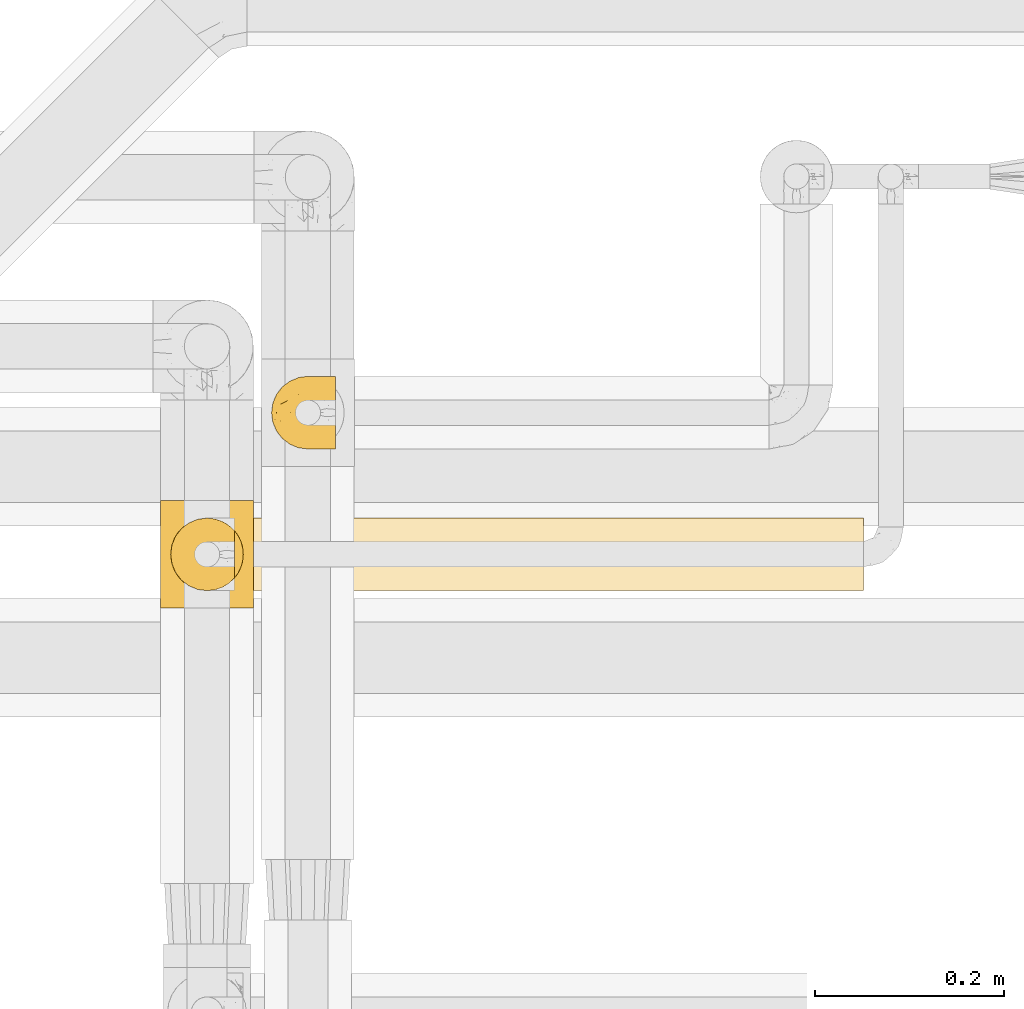
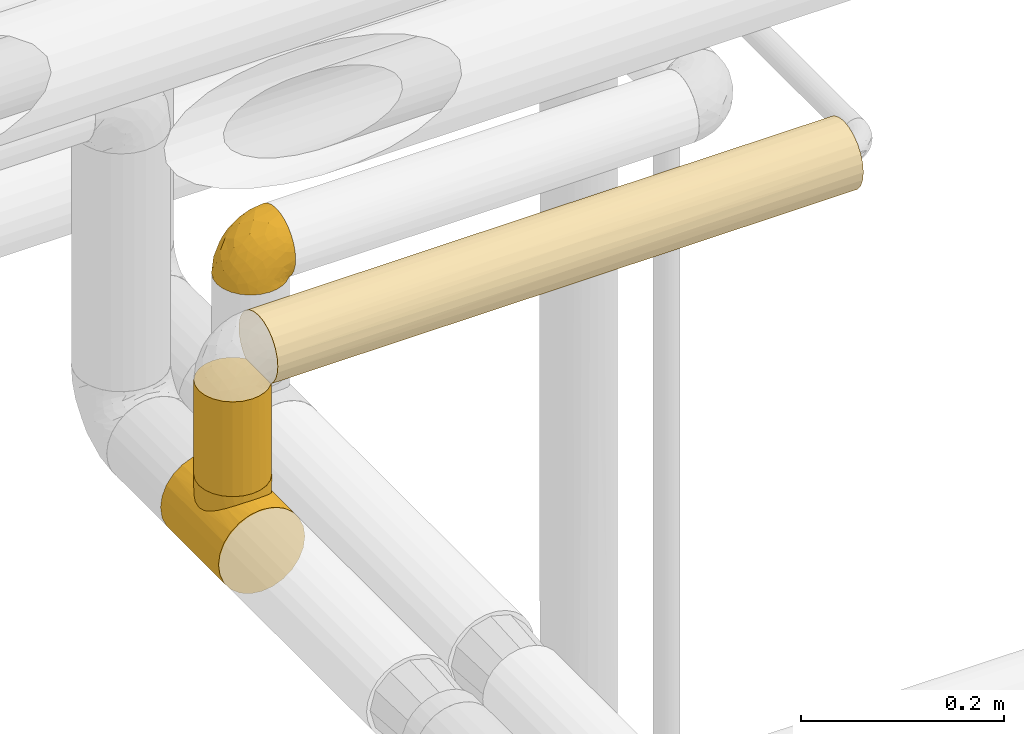
# One storey, part 374 of 827: 4 coverings.
"""IFC2X3 building model written with IfcOpenShell, lengths in millimetres."""

from ifc_helpers import new_model, entity, si_unit, converted_unit, derived_unit, direction, frame, origin, place, context, subcontext, project, spatial, faceted_brep, element, save


model = new_model("IFC2X3")

# Units and contexts
model_context = context("Model", 3, precision=0.01, world=origin(), true_north=direction((6.12303176911189e-17, 1.0)))
body_context = subcontext(model_context, "Body", "Model", "MODEL_VIEW")
ifc_project = project(units=[si_unit("LENGTHUNIT", "METRE", prefix="MILLI"), si_unit("AREAUNIT", "SQUARE_METRE"), si_unit("VOLUMEUNIT", "CUBIC_METRE"), converted_unit("PLANEANGLEUNIT", "DEGREE", entity("IfcRatioMeasure", 0.0174532925199433), si_unit("PLANEANGLEUNIT", "RADIAN"), dimensions=[0, 0, 0, 0, 0, 0, 0]), si_unit("MASSUNIT", "GRAM", prefix="KILO"), derived_unit("MASSDENSITYUNIT", [(si_unit("MASSUNIT", "GRAM", prefix="KILO"), 1), (si_unit("LENGTHUNIT", "METRE"), -3)]), derived_unit("MOMENTOFINERTIAUNIT", [(si_unit("LENGTHUNIT", "METRE"), 4)]), si_unit("TIMEUNIT", "SECOND"), si_unit("FREQUENCYUNIT", "HERTZ"), si_unit("THERMODYNAMICTEMPERATUREUNIT", "DEGREE_CELSIUS"), derived_unit("THERMALTRANSMITTANCEUNIT", [(si_unit("MASSUNIT", "GRAM", prefix="KILO"), 1), (si_unit("THERMODYNAMICTEMPERATUREUNIT", "KELVIN"), -1), (si_unit("TIMEUNIT", "SECOND"), -3)]), derived_unit("VOLUMETRICFLOWRATEUNIT", [(si_unit("LENGTHUNIT", "METRE"), 3), (si_unit("TIMEUNIT", "SECOND"), -1)]), derived_unit("MASSFLOWRATEUNIT", [(si_unit("MASSUNIT", "GRAM", prefix="KILO"), 1), (si_unit("TIMEUNIT", "SECOND"), -1)]), derived_unit("ROTATIONALFREQUENCYUNIT", [(si_unit("TIMEUNIT", "SECOND"), -1)]), si_unit("ELECTRICCURRENTUNIT", "AMPERE"), si_unit("ELECTRICVOLTAGEUNIT", "VOLT"), si_unit("POWERUNIT", "WATT"), si_unit("FORCEUNIT", "NEWTON", prefix="KILO"), si_unit("ILLUMINANCEUNIT", "LUX"), si_unit("LUMINOUSFLUXUNIT", "LUMEN"), si_unit("LUMINOUSINTENSITYUNIT", "CANDELA"), derived_unit("USERDEFINED", [(si_unit("MASSUNIT", "GRAM", prefix="KILO"), -1), (si_unit("LENGTHUNIT", "METRE"), -2), (si_unit("TIMEUNIT", "SECOND"), 3), (si_unit("LUMINOUSFLUXUNIT", "LUMEN"), 1)]), derived_unit("LINEARVELOCITYUNIT", [(si_unit("LENGTHUNIT", "METRE"), 1), (si_unit("TIMEUNIT", "SECOND"), -1)]), si_unit("PRESSUREUNIT", "PASCAL"), derived_unit("USERDEFINED", [(si_unit("LENGTHUNIT", "METRE"), -2), (si_unit("MASSUNIT", "GRAM", prefix="KILO"), 1), (si_unit("TIMEUNIT", "SECOND"), -2)]), derived_unit("LINEARFORCEUNIT", [(si_unit("MASSUNIT", "GRAM", prefix="KILO"), 1), (si_unit("LENGTHUNIT", "METRE"), 1), (si_unit("TIMEUNIT", "SECOND"), -2), (si_unit("LENGTHUNIT", "METRE"), -1)]), derived_unit("PLANARFORCEUNIT", [(si_unit("MASSUNIT", "GRAM", prefix="KILO"), 1), (si_unit("LENGTHUNIT", "METRE"), 1), (si_unit("TIMEUNIT", "SECOND"), -2), (si_unit("LENGTHUNIT", "METRE"), -2)])], contexts=[model_context])

# Site, building, storey
site_placement = place(None, origin())
site = spatial("IfcSite", under=ifc_project, at=site_placement, CompositionType="ELEMENT")
building_placement = place(site_placement, origin())
building = spatial("IfcBuilding", under=site, at=building_placement, CompositionType="ELEMENT")
storey_placement = place(building_placement, frame((0.0, 0.0, 28200.0)))
storey = spatial("IfcBuildingStorey", under=building, at=storey_placement, Name="08", CompositionType="ELEMENT", Elevation=28200.0)

# Coverings
covering_1_placement = place(storey_placement, frame((41436.17, 18826.17, 3169.3)))
element("IfcCovering", 1, at=covering_1_placement, inside=storey, Name=":ADSK_", ObjectType=":ADSK_", PredefinedType="INSULATION", context=body_context, shape_type="Brep", body=[
    faceted_brep([(69.15, 74.68, 47.38), (69.15, 70.1, 54.67), (69.15, 64.01, 60.76), (69.15, 56.72, 65.34), (69.15, 48.6, 68.18), (69.15, 40.05, 69.15), (69.15, 31.49, 68.18), (69.15, 23.36, 65.33), (69.15, 16.07, 60.75), (69.15, 9.98, 54.66), (69.15, 5.4, 47.37), (69.15, 2.56, 39.25), (69.15, 1.6, 30.7), (69.15, 2.46, 22.59), (69.15, 5.01, 14.86), (69.15, 9.13, 7.84), (69.15, 14.62, 1.85), (69.15, 16.82, 1.85), (69.15, 18.56, 1.85), (69.15, 20.52, 1.85), (69.15, 22.49, 1.85), (69.15, 24.46, 1.85), (69.15, 26.42, 1.85), (69.15, 28.39, 1.85), (69.15, 30.36, 1.85), (69.15, 32.55, 1.85), (69.15, 34.75, 1.85), (69.15, 36.94, 1.85), (69.15, 39.13, 1.85), (69.15, 41.33, 1.85), (69.15, 43.52, 1.85), (69.15, 45.72, 1.85), (69.15, 47.91, 1.85), (69.15, 50.11, 1.85), (69.15, 52.3, 1.85), (69.15, 54.49, 1.85), (69.15, 56.69, 1.85), (69.15, 58.88, 1.85), (69.15, 61.08, 1.85), (69.15, 63.27, 1.85), (69.15, 65.47, 1.85), (69.15, 70.97, 7.85), (69.15, 75.09, 14.88), (69.15, 77.64, 22.61), (69.15, 78.5, 30.7), (69.15, 77.53, 39.26), (68.89, 14.62, 1.6), (62.89, 9.12, 1.6), (55.87, 5.0, 1.6), (48.14, 2.46, 1.6), (40.05, 1.6, 1.6), (30.09, 2.91, 1.6), (20.82, 6.75, 1.6), (12.86, 12.86, 1.6), (6.75, 20.82, 1.6), (2.91, 30.09, 1.6), (1.6, 40.05, 1.6), (2.91, 50.0, 1.6), (6.75, 59.27, 1.6), (12.86, 67.23, 1.6), (20.82, 73.34, 1.6), (30.09, 77.19, 1.6), (40.05, 78.5, 1.6), (48.14, 77.63, 1.6), (55.87, 75.09, 1.6), (62.89, 70.97, 1.6), (68.89, 65.47, 1.6), (68.89, 63.27, 1.6), (68.89, 62.29, 1.6), (68.89, 60.7, 1.6), (68.89, 59.11, 1.6), (68.89, 57.52, 1.6), (68.89, 55.93, 1.6), (68.89, 54.34, 1.6), (68.89, 52.76, 1.6), (68.89, 51.17, 1.6), (68.89, 49.58, 1.6), (68.89, 47.99, 1.6), (68.89, 46.4, 1.6), (68.89, 44.81, 1.6), (68.89, 43.22, 1.6), (68.89, 41.63, 1.6), (68.89, 40.05, 1.6), (68.89, 38.46, 1.6), (68.89, 36.87, 1.6), (68.89, 35.28, 1.6), (68.89, 33.69, 1.6), (68.89, 32.1, 1.6), (68.89, 30.51, 1.6), (68.89, 28.92, 1.6), (68.89, 27.33, 1.6), (68.89, 25.37, 1.6), (68.89, 23.4, 1.6), (68.89, 21.21, 1.6), (68.89, 19.01, 1.6), (68.89, 16.82, 1.6), (68.97, 42.32, 1.78), (68.96, 44.02, 1.77), (68.97, 47.13, 1.78), (68.97, 48.74, 1.77), (68.98, 23.57, 1.79), (68.97, 25.13, 1.78), (68.96, 61.34, 1.76), (68.96, 22.02, 1.77), (68.96, 29.72, 1.77), (68.96, 56.73, 1.76), (68.96, 55.14, 1.77), (68.96, 37.66, 1.77), (69.0, 64.12, 1.8), (68.96, 28.13, 1.76), (68.96, 26.62, 1.77), (68.97, 31.46, 1.78), (68.96, 16.16, 1.77), (68.96, 39.16, 1.77), (68.96, 50.37, 1.76), (68.97, 17.69, 1.77), (68.97, 19.17, 1.78), (68.97, 62.78, 1.77), (68.96, 58.35, 1.77), (68.96, 45.53, 1.77), (68.97, 59.91, 1.78), (68.97, 65.47, 1.77), (69.02, 65.47, 1.8), (69.08, 65.47, 1.82), (68.97, 14.62, 1.77), (68.94, 14.62, 1.72), (68.92, 14.62, 1.66), (68.96, 20.59, 1.76), (68.96, 32.99, 1.77), (68.95, 34.48, 1.76), (68.96, 51.91, 1.77), (68.92, 65.47, 1.66), (68.94, 65.47, 1.72), (68.98, 53.48, 1.78), (69.08, 14.62, 1.82), (69.02, 14.62, 1.8), (68.96, 40.77, 1.77), (68.97, 35.97, 1.78), (61.33, 7.84, 3.72), (53.1, 3.53, 7.41), (63.33, 8.32, 6.13), (55.53, 2.19, 19.34), (63.33, 3.53, 17.64), (54.6, 1.6, 26.8), (41.99, 1.6, 8.87), (57.07, 4.57, 9.2), (57.95, 3.96, 12.79), (51.56, 2.28, 14.62), (41.58, 1.6, 7.34), (61.7, 7.69, 5.33), (65.0, 8.32, 7.7), (67.02, 7.84, 9.41), (61.87, 1.6, 28.75), (49.27, 1.6, 21.47), (43.94, 1.6, 16.15), (61.21, 4.34, 14.14), (63.4, 1.6, 29.16), (33.11, 29.63, 57.02), (52.82, 27.34, 64.92), (43.3, 40.05, 64.0), (33.73, 2.39, 11.92), (36.52, 2.43, 19.16), (24.87, 9.07, 28.65), (14.17, 16.64, 24.62), (18.43, 9.54, 15.19), (28.67, 4.52, 18.36), (26.0, 4.52, 9.2), (49.25, 7.49, 46.98), (59.72, 7.49, 50.24), (55.1, 12.85, 56.1), (44.72, 2.35, 28.97), (34.15, 22.66, 54.46), (5.25, 32.9, 21.34), (6.75, 25.33, 18.4), (55.54, 40.05, 66.44), (10.47, 16.64, 12.07), (25.49, 19.99, 45.49), (35.53, 16.37, 50.57), (48.22, 3.26, 36.04), (58.71, 3.75, 42.07), (57.42, 19.58, 62.12), (34.84, 7.5, 37.37), (36.87, 4.04, 29.39), (45.01, 13.94, 53.59), (44.4, 19.58, 58.06), (23.96, 28.21, 49.27), (11.2, 24.75, 29.63), (10.56, 31.42, 33.21), (16.81, 26.2, 40.1), (17.38, 33.36, 44.08), (21.38, 40.05, 49.36), (32.34, 40.05, 56.68), (4.3, 40.05, 15.2), (20.65, 16.14, 35.57), (29.66, 12.85, 41.7), (39.6, 10.47, 46.4), (42.55, 6.49, 41.41), (6.74, 40.05, 27.45), (14.06, 40.05, 38.4), (26.84, 75.57, 12.99), (5.28, 47.37, 21.33), (18.52, 52.91, 42.89), (33.13, 50.46, 57.04), (55.1, 67.23, 56.11), (57.43, 60.5, 62.13), (20.72, 70.55, 21.89), (11.46, 63.45, 16.62), (17.69, 62.61, 32.9), (49.26, 72.6, 46.99), (59.73, 72.6, 50.25), (58.71, 76.34, 42.08), (29.72, 59.34, 49.91), (35.35, 77.76, 15.6), (43.94, 78.5, 16.15), (41.99, 78.5, 8.87), (63.4, 78.5, 29.16), (4.93, 53.16, 13.16), (17.46, 70.55, 10.83), (10.94, 48.88, 33.8), (8.92, 54.76, 25.02), (52.83, 52.74, 64.92), (29.34, 71.93, 32.83), (30.26, 75.79, 20.56), (44.4, 60.5, 58.07), (39.06, 77.86, 21.46), (43.06, 77.64, 28.1), (54.6, 78.5, 26.8), (49.27, 78.5, 21.47), (42.69, 67.23, 51.29), (48.2, 76.82, 36.04), (61.87, 78.5, 28.75), (33.44, 77.8, 8.45), (29.67, 67.23, 41.73), (38.5, 73.2, 39.27), (23.35, 67.66, 33.56), (34.97, 75.99, 27.29), (53.1, 76.57, 7.41), (59.68, 73.21, 3.51), (62.19, 71.93, 4.68), (64.11, 71.07, 5.52), (57.97, 75.09, 8.75), (57.95, 76.13, 12.79), (63.33, 76.57, 17.65), (51.77, 77.69, 13.9), (67.02, 72.26, 9.42), (64.98, 71.77, 7.68), (55.53, 77.9, 19.33), (61.22, 75.75, 14.13)], [[[0, 1, 2, 3, 4, 5, 6, 7, 8, 9, 10, 11, 12, 13, 14, 15, 16, 17, 18, 19, 20, 21, 22, 23, 24, 25, 26, 27, 28, 29, 30, 31, 32, 33, 34, 35, 36, 37, 38, 39, 40, 41, 42, 43, 44, 45]], [[46, 47, 48, 49, 50, 51, 52, 53, 54, 55, 56, 57, 58, 59, 60, 61, 62, 63, 64, 65, 66, 67, 68, 69, 70, 71, 72, 73, 74, 75, 76, 77, 78, 79, 80, 81, 82, 83, 84, 85, 86, 87, 88, 89, 90, 91, 92, 93, 94, 95]], [[96, 97, 30]], [[98, 77, 99]], [[100, 101, 21]], [[69, 68, 102]], [[20, 19, 103]], [[24, 23, 104]], [[20, 103, 100]], [[72, 105, 106]], [[84, 83, 107]], [[89, 88, 104]], [[108, 67, 66]], [[109, 110, 90]], [[111, 25, 24]], [[112, 17, 16]], [[82, 113, 83]], [[109, 23, 22]], [[114, 76, 75]], [[105, 36, 106]], [[104, 111, 24]], [[18, 115, 116]], [[97, 96, 80]], [[67, 108, 117]], [[105, 71, 118]], [[31, 97, 119]], [[102, 120, 69]], [[108, 121, 122, 123, 40]], [[112, 95, 115]], [[17, 115, 18]], [[94, 116, 115]], [[117, 68, 67]], [[38, 117, 39]], [[112, 124, 125, 126, 46]], [[17, 112, 115]], [[70, 120, 118]], [[39, 117, 108]], [[120, 38, 37]], [[120, 37, 118]], [[120, 70, 69]], [[116, 94, 127]], [[128, 86, 129]], [[117, 38, 102]], [[74, 130, 75]], [[99, 33, 32]], [[115, 95, 94]], [[39, 108, 40]], [[108, 66, 131, 132, 121]], [[105, 72, 71]], [[118, 37, 36]], [[71, 70, 118]], [[35, 106, 36]], [[36, 105, 118]], [[35, 133, 106]], [[74, 73, 133]], [[106, 133, 73]], [[99, 114, 33]], [[133, 35, 34]], [[73, 72, 106]], [[95, 112, 46]], [[112, 16, 134, 135, 124]], [[130, 114, 75]], [[99, 76, 114]], [[114, 130, 33]], [[34, 33, 130]], [[78, 77, 98]], [[98, 119, 78]], [[130, 133, 34]], [[133, 130, 74]], [[79, 97, 80]], [[98, 99, 32]], [[98, 32, 31]], [[77, 76, 99]], [[97, 79, 119]], [[136, 96, 29]], [[30, 97, 31]], [[136, 29, 28]], [[81, 80, 96]], [[29, 96, 30]], [[31, 119, 98]], [[119, 79, 78]], [[96, 136, 81]], [[82, 81, 136]], [[113, 107, 83]], [[84, 107, 137]], [[107, 27, 137]], [[113, 28, 107]], [[27, 107, 28]], [[85, 84, 137]], [[137, 27, 26]], [[113, 136, 28]], [[136, 113, 82]], [[109, 89, 104]], [[86, 85, 129]], [[89, 109, 90]], [[111, 87, 128]], [[26, 129, 137]], [[88, 111, 104]], [[25, 111, 128]], [[22, 110, 109]], [[23, 109, 104]], [[110, 91, 90]], [[100, 92, 101]], [[110, 22, 101]], [[91, 110, 101]], [[116, 19, 18]], [[111, 88, 87]], [[127, 103, 19]], [[25, 128, 26]], [[86, 128, 87]], [[128, 129, 26]], [[137, 129, 85]], [[120, 102, 38]], [[117, 102, 68]], [[91, 101, 92]], [[21, 101, 22]], [[93, 92, 103]], [[100, 21, 20]], [[100, 103, 92]], [[127, 93, 103]], [[93, 127, 94]], [[116, 127, 19]], [[126, 138, 47]], [[48, 138, 139]], [[140, 125, 124]], [[141, 142, 143]], [[144, 49, 139]], [[145, 140, 146]], [[48, 139, 49]], [[139, 145, 147]], [[49, 144, 148, 50]], [[126, 125, 149]], [[14, 13, 142]], [[150, 146, 140]], [[149, 140, 145]], [[151, 150, 135]], [[151, 14, 142]], [[16, 15, 134]], [[13, 152, 142]], [[124, 150, 140]], [[141, 143, 153]], [[14, 151, 15]], [[15, 151, 134]], [[47, 46, 126]], [[139, 154, 144]], [[138, 48, 47]], [[125, 140, 149]], [[135, 134, 151]], [[146, 155, 141]], [[145, 146, 147]], [[149, 139, 138]], [[147, 153, 154]], [[147, 146, 141]], [[139, 147, 154]], [[139, 149, 145]], [[149, 138, 126]], [[147, 141, 153]], [[146, 150, 155]], [[151, 155, 150]], [[142, 141, 155]], [[13, 12, 156, 152]], [[152, 143, 142]], [[151, 142, 155]], [[150, 124, 135]], [[157, 158, 159]], [[160, 154, 161]], [[162, 163, 164]], [[165, 166, 160]], [[167, 168, 169]], [[153, 170, 161]], [[156, 12, 11]], [[158, 157, 171]], [[172, 55, 173]], [[158, 6, 174]], [[175, 54, 53]], [[52, 166, 164]], [[52, 164, 53]], [[54, 175, 173]], [[166, 52, 51]], [[176, 177, 171]], [[178, 143, 179]], [[156, 11, 179]], [[8, 7, 180]], [[169, 9, 8]], [[179, 143, 152, 156]], [[179, 11, 10]], [[168, 179, 10]], [[181, 162, 182]], [[179, 167, 178]], [[183, 184, 177]], [[183, 169, 184]], [[176, 171, 185]], [[172, 186, 187]], [[158, 7, 6]], [[159, 158, 174]], [[184, 180, 158]], [[54, 173, 55]], [[180, 169, 8]], [[188, 189, 187]], [[9, 168, 10]], [[186, 188, 187]], [[190, 157, 159, 191]], [[55, 172, 192]], [[176, 193, 194]], [[161, 170, 182]], [[162, 164, 165]], [[175, 164, 163]], [[51, 50, 148]], [[167, 195, 196]], [[178, 182, 170]], [[6, 5, 174]], [[158, 180, 7]], [[169, 180, 184]], [[169, 168, 9]], [[179, 168, 167]], [[182, 162, 165]], [[162, 194, 193]], [[161, 165, 160]], [[195, 181, 196]], [[192, 172, 197]], [[192, 56, 55]], [[189, 190, 198]], [[198, 197, 187]], [[172, 187, 197]], [[185, 189, 188]], [[198, 187, 189]], [[186, 172, 173]], [[173, 163, 186]], [[193, 186, 163]], [[176, 185, 188]], [[185, 157, 190]], [[188, 186, 193]], [[177, 176, 194]], [[188, 193, 176]], [[162, 193, 163]], [[195, 177, 194]], [[171, 177, 184]], [[181, 195, 194]], [[183, 167, 169]], [[162, 181, 194]], [[196, 182, 178]], [[158, 171, 184]], [[171, 157, 185]], [[177, 195, 183]], [[167, 183, 195]], [[182, 196, 181]], [[178, 170, 143]], [[178, 167, 196]], [[164, 175, 53]], [[173, 175, 163]], [[160, 51, 148]], [[164, 166, 165]], [[51, 160, 166]], [[160, 148, 144, 154]], [[153, 161, 154]], [[182, 165, 161]], [[190, 189, 185]], [[143, 170, 153]], [[60, 199, 61]], [[197, 200, 192]], [[201, 190, 202]], [[200, 57, 192]], [[203, 204, 2]], [[205, 206, 207]], [[208, 209, 210]], [[211, 207, 201]], [[212, 213, 214]], [[45, 215, 210]], [[216, 206, 58]], [[45, 44, 215]], [[59, 217, 60]], [[60, 217, 199]], [[0, 45, 210]], [[218, 201, 219]], [[202, 159, 220]], [[205, 221, 222]], [[223, 204, 203]], [[1, 203, 2]], [[57, 200, 216]], [[220, 3, 204]], [[220, 174, 4]], [[1, 0, 209]], [[212, 224, 213]], [[225, 226, 227]], [[228, 223, 203]], [[208, 210, 229]], [[210, 226, 229]], [[3, 220, 4]], [[58, 206, 59]], [[209, 203, 1]], [[202, 220, 223]], [[228, 203, 208]], [[202, 211, 201]], [[3, 2, 204]], [[202, 190, 191, 159]], [[210, 215, 230, 226]], [[199, 212, 231]], [[232, 233, 221]], [[233, 208, 229]], [[207, 206, 219]], [[217, 206, 205]], [[227, 224, 225]], [[233, 232, 228]], [[201, 207, 219]], [[234, 232, 221]], [[218, 219, 200]], [[202, 223, 211]], [[174, 220, 159]], [[174, 5, 4]], [[61, 231, 62]], [[220, 204, 223]], [[210, 209, 0]], [[203, 209, 208]], [[225, 233, 229]], [[224, 227, 213]], [[221, 233, 235]], [[57, 56, 192]], [[198, 218, 197]], [[200, 219, 216]], [[201, 198, 190]], [[197, 218, 200]], [[198, 201, 218]], [[206, 216, 219]], [[58, 57, 216]], [[231, 212, 214]], [[222, 212, 199]], [[228, 211, 223]], [[207, 211, 232]], [[62, 231, 214]], [[199, 231, 61]], [[233, 228, 208]], [[211, 228, 232]], [[222, 221, 235]], [[234, 205, 207]], [[206, 217, 59]], [[199, 217, 205]], [[205, 222, 199]], [[224, 222, 235]], [[222, 224, 212]], [[224, 235, 225]], [[233, 225, 235]], [[226, 225, 229]], [[205, 234, 221]], [[207, 232, 234]], [[63, 214, 236]], [[214, 213, 236]], [[214, 63, 62]], [[237, 236, 238]], [[238, 132, 131]], [[236, 237, 64]], [[239, 240, 241]], [[63, 236, 64]], [[131, 66, 65]], [[237, 131, 65]], [[242, 230, 43]], [[237, 65, 64]], [[239, 121, 132]], [[42, 242, 43]], [[241, 240, 243]], [[41, 123, 244]], [[43, 230, 215, 44]], [[244, 122, 245]], [[227, 246, 243]], [[245, 241, 247]], [[121, 239, 245]], [[41, 40, 123]], [[132, 238, 239]], [[244, 42, 41]], [[131, 237, 238]], [[240, 239, 238]], [[245, 239, 241]], [[247, 241, 246]], [[247, 244, 245]], [[238, 236, 240]], [[243, 236, 213]], [[236, 243, 240]], [[246, 241, 243]], [[243, 213, 227]], [[226, 242, 246]], [[227, 226, 246]], [[246, 242, 247]], [[244, 247, 242]], [[242, 226, 230]], [[42, 244, 242]], [[122, 244, 123]], [[122, 121, 245]]]),
])
covering_2_placement = place(storey_placement, frame((41318.63, 18659.22, 2949.25)))
element("IfcCovering", 2, at=covering_2_placement, inside=storey, Name=":ADSK_", ObjectType=":ADSK_", PredefinedType="INSULATION", context=body_context, shape_type="Brep", body=[
    faceted_brep([(26.17, 0.0, 8.18), (38.02, 0.0, 3.27), (50.75, 0.0, 1.6), (63.47, 0.0, 3.27), (75.32, 0.0, 8.18), (85.5, 0.0, 15.99), (93.31, 0.0, 26.17), (98.22, 0.0, 38.02), (99.9, 0.0, 50.75), (98.22, 0.0, 63.47), (93.31, 0.0, 75.32), (85.5, 0.0, 85.5), (80.41, 0.0, 89.4), (75.32, 0.0, 93.31), (69.39, 0.0, 95.77), (63.47, 0.0, 98.22), (60.29, 0.0, 98.64), (57.11, 0.0, 99.06), (53.93, 0.0, 99.48), (50.75, 0.0, 99.9), (47.57, 0.0, 99.48), (44.38, 0.0, 99.06), (41.2, 0.0, 98.64), (38.02, 0.0, 98.22), (32.1, 0.0, 95.77), (26.17, 0.0, 93.31), (21.08, 0.0, 89.4), (15.99, 0.0, 85.5), (8.18, 0.0, 75.32), (3.27, 0.0, 63.47), (1.6, 0.0, 50.75), (3.27, 0.0, 38.02), (8.18, 0.0, 26.17), (15.99, 0.0, 15.99), (98.22, 114.0, 38.02), (93.31, 114.0, 26.17), (85.5, 114.0, 15.99), (75.32, 114.0, 8.18), (63.47, 114.0, 3.27), (50.75, 114.0, 1.6), (38.02, 114.0, 3.27), (26.17, 114.0, 8.18), (15.99, 114.0, 15.99), (8.18, 114.0, 26.17), (3.27, 114.0, 38.02), (1.6, 114.0, 50.75), (3.27, 114.0, 63.47), (8.18, 114.0, 75.32), (15.99, 114.0, 85.5), (21.08, 114.0, 89.4), (26.17, 114.0, 93.31), (32.1, 114.0, 95.77), (38.02, 114.0, 98.22), (41.2, 114.0, 98.64), (44.38, 114.0, 99.06), (47.57, 114.0, 99.48), (50.75, 114.0, 99.9), (53.93, 114.0, 99.48), (57.11, 114.0, 99.06), (60.29, 114.0, 98.64), (63.47, 114.0, 98.22), (69.39, 114.0, 95.77), (75.32, 114.0, 93.31), (80.41, 114.0, 89.4), (85.5, 114.0, 85.5), (93.31, 114.0, 75.32), (98.22, 114.0, 63.47), (99.9, 114.0, 50.75), (80.86, 80.91, 89.59), (85.26, 73.95, 85.74), (75.08, 86.77, 93.45), (67.99, 22.63, 96.77), (88.15, 65.92, 82.63), (89.2, 57.0, 81.36), (88.15, 48.08, 82.63), (50.75, 18.55, 99.9), (50.75, 95.45, 99.9), (80.86, 33.09, 89.59), (85.26, 40.05, 85.74), (75.08, 27.23, 93.45), (67.99, 91.37, 96.77), (63.86, 21.12, 97.92), (59.73, 94.39, 99.07), (55.24, 94.92, 99.48), (63.86, 92.88, 97.92), (59.73, 19.61, 99.07), (55.24, 19.08, 99.48), (46.25, 94.92, 99.48), (37.63, 92.88, 97.92), (26.41, 86.77, 93.45), (41.76, 94.39, 99.07), (33.5, 91.37, 96.77), (37.63, 21.12, 97.92), (41.76, 19.61, 99.07), (46.25, 19.08, 99.48), (26.41, 27.23, 93.45), (33.5, 22.63, 96.77), (20.63, 33.09, 89.59), (20.63, 80.91, 89.59), (16.23, 73.95, 85.74), (13.34, 65.92, 82.63), (12.3, 57.0, 81.36), (16.23, 40.05, 85.74), (13.34, 48.08, 82.63), (89.2, 57.0, 107.75), (87.89, 66.95, 107.75), (84.04, 76.22, 107.75), (77.93, 84.19, 107.75), (69.97, 90.3, 107.75), (60.7, 94.14, 107.75), (50.75, 95.45, 107.75), (40.79, 94.14, 107.75), (31.52, 90.3, 107.75), (23.56, 84.19, 107.75), (17.45, 76.22, 107.75), (13.61, 66.95, 107.75), (12.3, 57.0, 107.75), (13.61, 47.05, 107.75), (17.45, 37.77, 107.75), (23.56, 29.81, 107.75), (31.52, 23.7, 107.75), (40.79, 19.86, 107.75), (50.75, 18.55, 107.75), (60.7, 19.86, 107.75), (69.97, 23.7, 107.75), (77.93, 29.81, 107.75), (84.04, 37.77, 107.75), (87.89, 47.05, 107.75)], [[[0, 1, 2, 3, 4, 5, 6, 7, 8, 9, 10, 11, 12, 13, 14, 15, 16, 17, 18, 19, 20, 21, 22, 23, 24, 25, 26, 27, 28, 29, 30, 31, 32, 33]], [[34, 35, 36, 37, 38, 39, 40, 41, 42, 43, 44, 45, 46, 47, 48, 49, 50, 51, 52, 53, 54, 55, 56, 57, 58, 59, 60, 61, 62, 63, 64, 65, 66, 67]], [[37, 36, 5, 4]], [[2, 39, 38, 3]], [[38, 37, 4, 3]], [[6, 35, 34, 7]], [[7, 34, 67, 8]], [[5, 36, 35, 6]], [[66, 9, 8, 67]], [[65, 10, 9, 66]], [[64, 68, 69]], [[63, 62, 70]], [[71, 15, 14]], [[69, 72, 64]], [[68, 64, 63]], [[64, 72, 65]], [[72, 73, 65]], [[74, 11, 10]], [[18, 75, 19]], [[76, 57, 56]], [[77, 11, 78]], [[78, 11, 74]], [[79, 12, 77]], [[74, 10, 73]], [[73, 10, 65]], [[70, 61, 80]], [[61, 70, 62]], [[80, 61, 60]], [[15, 71, 81]], [[82, 59, 58]], [[83, 57, 76]], [[84, 59, 82]], [[82, 58, 83]], [[83, 58, 57]], [[60, 84, 80]], [[17, 85, 86]], [[79, 13, 12]], [[59, 84, 60]], [[79, 14, 13]], [[14, 79, 71]], [[85, 17, 16]], [[77, 12, 11]], [[18, 17, 86]], [[15, 81, 16]], [[16, 81, 85]], [[75, 18, 86]], [[68, 63, 70]], [[54, 87, 55]], [[53, 52, 88]], [[76, 55, 87]], [[50, 89, 51]], [[54, 90, 87]], [[91, 51, 89]], [[91, 52, 51]], [[88, 90, 53]], [[92, 22, 93]], [[93, 21, 94]], [[75, 20, 19]], [[55, 76, 56]], [[20, 75, 94]], [[95, 25, 24]], [[90, 54, 53]], [[24, 23, 96]], [[95, 97, 26]], [[96, 23, 92]], [[89, 49, 98]], [[89, 50, 49]], [[94, 21, 20]], [[98, 48, 99]], [[48, 98, 49]], [[99, 48, 100]], [[52, 91, 88]], [[28, 47, 46, 29]], [[101, 100, 47]], [[47, 100, 48]], [[46, 45, 30, 29]], [[93, 22, 21]], [[102, 103, 27]], [[95, 24, 96]], [[26, 25, 95]], [[27, 97, 102]], [[103, 28, 27]], [[22, 92, 23]], [[101, 28, 103]], [[101, 47, 28]], [[97, 27, 26]], [[31, 44, 43, 32]], [[32, 43, 42, 33]], [[45, 44, 31, 30]], [[0, 41, 40, 1]], [[1, 40, 39, 2]], [[33, 42, 41, 0]], [[104, 105, 106, 107, 108, 109, 110, 111, 112, 113, 114, 115, 116, 117, 118, 119, 120, 121, 122, 123, 124, 125, 126, 127]], [[82, 110, 109]], [[80, 109, 108]], [[110, 82, 83, 76]], [[70, 80, 108]], [[109, 80, 84, 82]], [[108, 107, 70]], [[107, 106, 68]], [[106, 105, 69]], [[72, 105, 104]], [[68, 106, 69]], [[72, 69, 105]], [[73, 72, 104]], [[107, 68, 70]], [[74, 104, 127]], [[78, 127, 126]], [[73, 104, 74]], [[74, 127, 78]], [[126, 77, 78]], [[126, 125, 77]], [[79, 125, 124]], [[124, 123, 71]], [[122, 85, 123]], [[71, 79, 124]], [[122, 75, 86, 85]], [[123, 85, 81, 71]], [[125, 79, 77]], [[93, 122, 121]], [[96, 121, 120]], [[122, 93, 94, 75]], [[95, 96, 120]], [[121, 96, 92, 93]], [[120, 119, 95]], [[97, 119, 118]], [[118, 117, 102]], [[116, 103, 117]], [[97, 118, 102]], [[103, 102, 117]], [[101, 103, 116]], [[119, 97, 95]], [[100, 116, 115]], [[99, 115, 114]], [[101, 116, 100]], [[100, 115, 99]], [[114, 98, 99]], [[114, 113, 98]], [[89, 113, 112]], [[112, 111, 91]], [[110, 90, 111]], [[91, 89, 112]], [[110, 76, 87, 90]], [[111, 90, 88, 91]], [[113, 89, 98]]]),
])
covering_3_placement = place(storey_placement, frame((41396.88, 18676.23, 3159.95)))
element("IfcCovering", 3, at=covering_3_placement, inside=storey, Name=":ADSK_", ObjectType=":ADSK_", PredefinedType="INSULATION", context=body_context, shape_type="Brep", body=[
    faceted_brep([(1.59, 5.09, 23.98), (1.59, 2.48, 31.79), (1.59, 1.6, 39.99), (1.59, 2.9, 49.93), (1.59, 6.74, 59.19), (1.59, 12.84, 67.15), (1.59, 20.8, 73.25), (1.59, 30.06, 77.09), (1.59, 40.0, 78.39), (1.59, 49.93, 77.09), (1.59, 59.2, 73.25), (1.59, 67.15, 67.15), (1.59, 73.25, 59.19), (1.59, 77.09, 49.93), (1.59, 78.4, 39.99), (1.59, 77.51, 31.79), (1.59, 74.9, 23.98), (1.59, 70.68, 16.91), (1.6, 65.05, 10.89), (1.6, 14.94, 10.89), (1.59, 9.31, 16.91), (667.43, 2.9, 30.11), (667.43, 6.74, 20.85), (667.43, 12.84, 12.9), (667.43, 20.8, 6.8), (667.43, 30.06, 2.96), (667.43, 40.0, 1.65), (667.43, 49.93, 2.96), (667.43, 59.2, 6.8), (667.43, 67.15, 12.9), (667.43, 73.25, 20.85), (667.43, 77.09, 30.11), (667.42, 78.4, 40.05), (667.42, 77.09, 49.99), (667.42, 73.25, 59.25), (667.42, 67.15, 67.2), (667.42, 59.2, 73.31), (667.42, 49.93, 77.14), (667.42, 40.0, 78.45), (667.42, 30.06, 77.14), (667.42, 20.8, 73.31), (667.42, 12.84, 67.2), (667.42, 6.74, 59.25), (667.42, 2.9, 49.99), (667.42, 1.6, 40.05), (434.34, 78.4, 40.03), (10.9, 40.0, 1.6), (10.29, 46.78, 2.2), (227.27, 40.0, 1.61), (327.31, 76.41, 27.84), (217.97, 78.4, 40.01), (334.51, 78.4, 40.02), (448.7, 56.45, 5.34), (338.26, 62.56, 8.95), (380.22, 70.46, 16.65), (443.64, 40.0, 1.63), (8.5, 53.36, 4.0), (5.57, 59.51, 6.92), (216.21, 56.83, 5.5), (317.48, 50.2, 3.0), (317.48, 29.79, 3.0), (8.5, 26.63, 4.0), (10.29, 33.21, 2.2), (334.51, 1.6, 40.02), (217.97, 1.6, 40.01), (229.43, 23.18, 5.49), (5.57, 20.48, 6.92), (434.34, 1.6, 40.03), (338.26, 17.43, 8.95), (451.11, 23.54, 5.34), (380.22, 9.53, 16.65), (327.31, 3.58, 27.84), (326.15, 2.27, 47.21), (262.59, 4.52, 54.71), (467.93, 3.73, 52.65), (334.51, 9.53, 63.4), (262.59, 16.62, 70.48), (452.79, 13.8, 68.11), (447.91, 19.69, 72.63), (334.51, 25.3, 75.5), (459.34, 33.34, 77.85), (434.34, 40.0, 78.43), (334.51, 40.0, 78.42), (231.07, 32.5, 77.68), (217.96, 40.0, 78.41), (326.15, 47.19, 77.74), (262.58, 54.69, 75.49), (467.93, 52.61, 76.3), (334.51, 63.37, 70.49), (262.59, 70.46, 63.39), (452.79, 68.07, 66.23), (447.91, 72.59, 60.34), (334.51, 75.47, 54.72), (459.34, 77.81, 46.69), (231.07, 77.66, 47.51)], [[[0, 1, 2, 3, 4, 5, 6, 7, 8, 9, 10, 11, 12, 13, 14, 15, 16, 17, 18, 19, 20]], [[21, 22, 23, 24, 25, 26, 27, 28, 29, 30, 31, 32, 33, 34, 35, 36, 37, 38, 39, 40, 41, 42, 43, 44]], [[45, 32, 31]], [[46, 47, 48]], [[49, 50, 51, 45]], [[15, 14, 50]], [[27, 52, 28]], [[29, 53, 54]], [[26, 55, 27]], [[45, 31, 49]], [[54, 53, 18]], [[15, 49, 16]], [[16, 49, 54]], [[30, 49, 31]], [[17, 16, 54]], [[30, 29, 54]], [[56, 57, 58]], [[56, 58, 59]], [[15, 50, 49]], [[48, 47, 59]], [[52, 58, 53]], [[47, 56, 59]], [[29, 28, 53]], [[18, 53, 57]], [[54, 18, 17]], [[52, 59, 58]], [[58, 57, 53]], [[27, 55, 59]], [[59, 55, 48]], [[59, 52, 27]], [[53, 28, 52]], [[49, 30, 54]], [[60, 61, 62]], [[1, 63, 64, 2]], [[25, 55, 26]], [[61, 65, 66]], [[21, 44, 67, 63]], [[24, 68, 69]], [[23, 22, 70]], [[65, 69, 68]], [[62, 48, 60]], [[65, 61, 60]], [[55, 25, 60]], [[24, 23, 68]], [[68, 19, 66]], [[60, 69, 65]], [[70, 68, 23]], [[25, 69, 60]], [[22, 21, 71]], [[48, 62, 46]], [[48, 55, 60]], [[71, 63, 1]], [[0, 20, 70]], [[19, 70, 20]], [[22, 71, 70]], [[0, 71, 1]], [[21, 63, 71]], [[70, 71, 0]], [[19, 68, 70]], [[68, 66, 65]], [[25, 24, 69]], [[43, 72, 67]], [[3, 72, 73]], [[74, 72, 43]], [[73, 75, 4]], [[73, 74, 75]], [[43, 67, 44]], [[3, 2, 64]], [[41, 75, 42]], [[72, 64, 63, 67]], [[75, 5, 4]], [[4, 3, 73]], [[76, 77, 78]], [[43, 42, 74]], [[79, 40, 39]], [[79, 6, 76]], [[77, 76, 75]], [[80, 38, 81, 82]], [[5, 75, 76]], [[78, 79, 76]], [[64, 72, 3]], [[6, 5, 76]], [[79, 83, 7]], [[6, 79, 7]], [[73, 72, 74]], [[82, 83, 80]], [[83, 8, 7]], [[75, 74, 42]], [[75, 41, 77]], [[40, 77, 41]], [[77, 40, 78]], [[40, 79, 78]], [[80, 79, 39]], [[83, 82, 84, 8]], [[79, 80, 83]], [[38, 80, 39]], [[37, 85, 81]], [[9, 85, 86]], [[87, 85, 37]], [[86, 88, 10]], [[86, 87, 88]], [[37, 81, 38]], [[9, 8, 84]], [[35, 88, 36]], [[85, 84, 82, 81]], [[88, 11, 10]], [[10, 9, 86]], [[89, 90, 91]], [[37, 36, 87]], [[92, 34, 33]], [[92, 12, 89]], [[90, 89, 88]], [[93, 32, 45, 51]], [[11, 88, 89]], [[91, 92, 89]], [[84, 85, 9]], [[12, 11, 89]], [[92, 94, 13]], [[12, 92, 13]], [[86, 85, 87]], [[51, 94, 93]], [[94, 14, 13]], [[88, 87, 36]], [[88, 35, 90]], [[34, 90, 35]], [[90, 34, 91]], [[34, 92, 91]], [[93, 92, 33]], [[94, 51, 50, 14]], [[92, 93, 94]], [[32, 93, 33]], [[18, 57, 56, 47, 46, 62, 61, 66, 19]]]),
])
covering_4_placement = place(storey_placement, frame((41329.38, 18676.23, 3057.0)))
element("IfcCovering", 4, at=covering_4_placement, inside=storey, Name=":ADSK_", ObjectType=":ADSK_", PredefinedType="INSULATION", context=body_context, shape_type="Brep", body=[
    faceted_brep([(2.9, 30.06, 0.0), (1.6, 40.0, 0.0), (2.9, 49.93, 0.0), (6.74, 59.2, 0.0), (12.84, 67.15, 0.0), (20.8, 73.25, 0.0), (30.06, 77.09, 0.0), (40.0, 78.4, 0.0), (49.93, 77.09, 0.0), (59.2, 73.25, 0.0), (67.15, 67.15, 0.0), (73.25, 59.2, 0.0), (77.09, 49.93, 0.0), (78.4, 40.0, 0.0), (77.09, 30.06, 0.0), (73.25, 20.8, 0.0), (67.15, 12.84, 0.0), (59.2, 6.74, 0.0), (49.93, 2.9, 0.0), (40.0, 1.6, 0.0), (30.06, 2.9, 0.0), (20.8, 6.74, 0.0), (12.84, 12.84, 0.0), (6.74, 20.8, 0.0), (2.9, 30.06, 113.84), (6.74, 20.8, 113.84), (12.84, 12.84, 113.84), (20.8, 6.74, 113.84), (30.06, 2.9, 113.84), (40.0, 1.6, 113.84), (48.2, 2.48, 113.84), (56.01, 5.09, 113.84), (63.08, 9.31, 113.84), (69.1, 14.94, 113.84), (69.1, 65.05, 113.84), (63.08, 70.68, 113.84), (56.01, 74.9, 113.84), (48.2, 77.51, 113.84), (40.0, 78.4, 113.84), (30.06, 77.09, 113.84), (20.8, 73.25, 113.84), (12.84, 67.15, 113.84), (6.74, 59.2, 113.84), (2.9, 49.93, 113.84), (1.6, 40.0, 113.84), (73.07, 59.51, 109.87), (76.0, 53.36, 106.94), (77.79, 46.78, 105.15), (78.4, 40.0, 104.54), (77.79, 33.21, 105.15), (76.0, 26.63, 106.94), (73.07, 20.48, 109.87)], [[[0, 1, 2, 3, 4, 5, 6, 7, 8, 9, 10, 11, 12, 13, 14, 15, 16, 17, 18, 19, 20, 21, 22, 23]], [[24, 25, 26, 27, 28, 29, 30, 31, 32, 33, 34, 35, 36, 37, 38, 39, 40, 41, 42, 43, 44]], [[38, 37, 7]], [[36, 35, 9]], [[37, 36, 8]], [[8, 7, 37]], [[9, 8, 36]], [[35, 10, 9]], [[35, 34, 10]], [[34, 45, 11]], [[46, 47, 12]], [[45, 46, 11]], [[11, 46, 12]], [[13, 12, 47]], [[48, 13, 47]], [[34, 11, 10]], [[49, 50, 14]], [[51, 33, 15]], [[50, 51, 15]], [[48, 49, 13]], [[13, 49, 14]], [[50, 15, 14]], [[33, 16, 15]], [[17, 32, 31]], [[18, 31, 30]], [[19, 30, 29]], [[16, 32, 17]], [[17, 31, 18]], [[30, 19, 18]], [[32, 16, 33]], [[20, 19, 29, 28]], [[21, 20, 28, 27]], [[27, 26, 22, 21]], [[0, 23, 25, 24]], [[1, 0, 24, 44]], [[26, 25, 23, 22]], [[2, 1, 44, 43]], [[3, 2, 43, 42]], [[42, 41, 4, 3]], [[6, 5, 40, 39]], [[7, 6, 39, 38]], [[41, 40, 5, 4]], [[33, 51, 50, 49, 48, 47, 46, 45, 34]]]),
])

save(model, "model.ifc")
